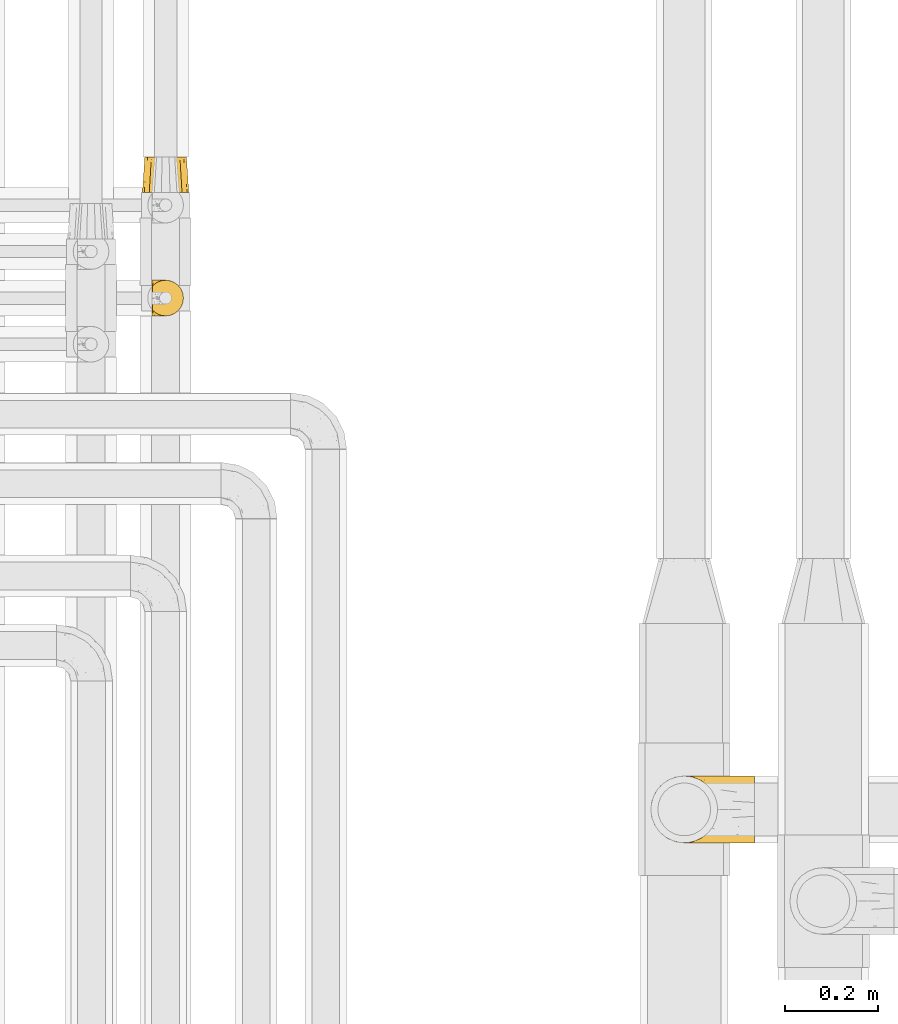
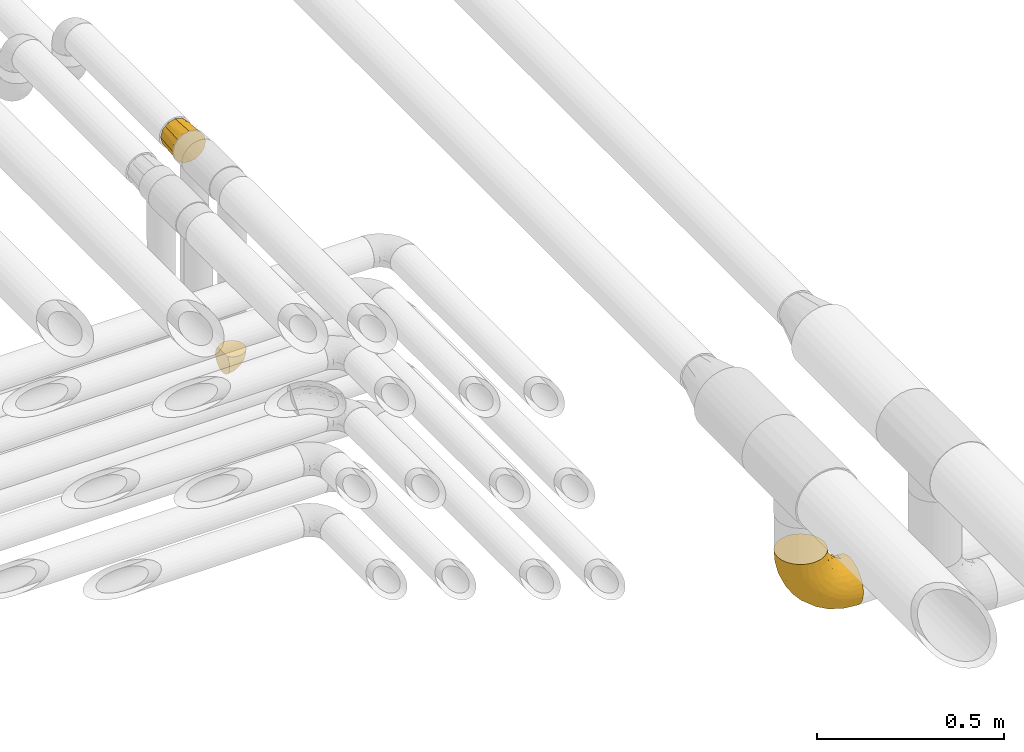
# One storey, part 348 of 827: 3 coverings.
"""IFC2X3 building model written with IfcOpenShell, lengths in millimetres."""

from ifc_helpers import new_model, entity, si_unit, converted_unit, derived_unit, direction, frame, origin, place, context, subcontext, project, spatial, faceted_brep, element, save


model = new_model("IFC2X3")

# Units and contexts
model_context = context("Model", 3, precision=0.01, world=origin(), true_north=direction((6.12303176911189e-17, 1.0)))
body_context = subcontext(model_context, "Body", "Model", "MODEL_VIEW")
ifc_project = project(units=[si_unit("LENGTHUNIT", "METRE", prefix="MILLI"), si_unit("AREAUNIT", "SQUARE_METRE"), si_unit("VOLUMEUNIT", "CUBIC_METRE"), converted_unit("PLANEANGLEUNIT", "DEGREE", entity("IfcRatioMeasure", 0.0174532925199433), si_unit("PLANEANGLEUNIT", "RADIAN"), dimensions=[0, 0, 0, 0, 0, 0, 0]), si_unit("MASSUNIT", "GRAM", prefix="KILO"), derived_unit("MASSDENSITYUNIT", [(si_unit("MASSUNIT", "GRAM", prefix="KILO"), 1), (si_unit("LENGTHUNIT", "METRE"), -3)]), derived_unit("MOMENTOFINERTIAUNIT", [(si_unit("LENGTHUNIT", "METRE"), 4)]), si_unit("TIMEUNIT", "SECOND"), si_unit("FREQUENCYUNIT", "HERTZ"), si_unit("THERMODYNAMICTEMPERATUREUNIT", "DEGREE_CELSIUS"), derived_unit("THERMALTRANSMITTANCEUNIT", [(si_unit("MASSUNIT", "GRAM", prefix="KILO"), 1), (si_unit("THERMODYNAMICTEMPERATUREUNIT", "KELVIN"), -1), (si_unit("TIMEUNIT", "SECOND"), -3)]), derived_unit("VOLUMETRICFLOWRATEUNIT", [(si_unit("LENGTHUNIT", "METRE"), 3), (si_unit("TIMEUNIT", "SECOND"), -1)]), derived_unit("MASSFLOWRATEUNIT", [(si_unit("MASSUNIT", "GRAM", prefix="KILO"), 1), (si_unit("TIMEUNIT", "SECOND"), -1)]), derived_unit("ROTATIONALFREQUENCYUNIT", [(si_unit("TIMEUNIT", "SECOND"), -1)]), si_unit("ELECTRICCURRENTUNIT", "AMPERE"), si_unit("ELECTRICVOLTAGEUNIT", "VOLT"), si_unit("POWERUNIT", "WATT"), si_unit("FORCEUNIT", "NEWTON", prefix="KILO"), si_unit("ILLUMINANCEUNIT", "LUX"), si_unit("LUMINOUSFLUXUNIT", "LUMEN"), si_unit("LUMINOUSINTENSITYUNIT", "CANDELA"), derived_unit("USERDEFINED", [(si_unit("MASSUNIT", "GRAM", prefix="KILO"), -1), (si_unit("LENGTHUNIT", "METRE"), -2), (si_unit("TIMEUNIT", "SECOND"), 3), (si_unit("LUMINOUSFLUXUNIT", "LUMEN"), 1)]), derived_unit("LINEARVELOCITYUNIT", [(si_unit("LENGTHUNIT", "METRE"), 1), (si_unit("TIMEUNIT", "SECOND"), -1)]), si_unit("PRESSUREUNIT", "PASCAL"), derived_unit("USERDEFINED", [(si_unit("LENGTHUNIT", "METRE"), -2), (si_unit("MASSUNIT", "GRAM", prefix="KILO"), 1), (si_unit("TIMEUNIT", "SECOND"), -2)]), derived_unit("LINEARFORCEUNIT", [(si_unit("MASSUNIT", "GRAM", prefix="KILO"), 1), (si_unit("LENGTHUNIT", "METRE"), 1), (si_unit("TIMEUNIT", "SECOND"), -2), (si_unit("LENGTHUNIT", "METRE"), -1)]), derived_unit("PLANARFORCEUNIT", [(si_unit("MASSUNIT", "GRAM", prefix="KILO"), 1), (si_unit("LENGTHUNIT", "METRE"), 1), (si_unit("TIMEUNIT", "SECOND"), -2), (si_unit("LENGTHUNIT", "METRE"), -2)])], contexts=[model_context])

# Site, building, storey
site_placement = place(None, origin())
site = spatial("IfcSite", under=ifc_project, at=site_placement, CompositionType="ELEMENT")
building_placement = place(site_placement, origin())
building = spatial("IfcBuilding", under=site, at=building_placement, CompositionType="ELEMENT")
storey_placement = place(building_placement, frame((0.0, 0.0, 28200.0)))
storey = spatial("IfcBuildingStorey", under=building, at=storey_placement, Name="08", CompositionType="ELEMENT", Elevation=28200.0)

# Coverings
covering_1_placement = place(storey_placement, frame((37674.55, 14212.87, 2426.25)))
element("IfcCovering", 1, at=covering_1_placement, inside=storey, Name=":ADSK_", ObjectType=":ADSK_", PredefinedType="INSULATION", context=body_context, shape_type="Brep", body=[
    faceted_brep([(225.75, 7.09, 46.13), (225.75, 13.76, 33.65), (225.75, 22.73, 22.72), (225.75, 33.67, 13.75), (225.75, 46.14, 7.08), (225.75, 59.68, 2.98), (225.75, 73.74, 1.6), (225.75, 87.82, 2.98), (225.75, 101.36, 7.09), (225.75, 113.84, 13.76), (225.75, 124.77, 22.73), (225.75, 133.74, 33.67), (225.75, 140.41, 46.14), (225.75, 144.51, 59.68), (225.75, 145.9, 73.74), (225.75, 144.51, 87.82), (225.75, 140.4, 101.36), (225.75, 133.73, 113.84), (225.75, 124.76, 124.77), (225.75, 113.82, 133.74), (225.75, 101.35, 140.41), (225.75, 87.81, 144.51), (225.75, 73.75, 145.9), (225.75, 59.67, 144.51), (225.75, 46.13, 140.4), (225.75, 33.65, 133.73), (225.75, 22.72, 124.76), (225.75, 13.75, 113.82), (225.75, 7.08, 101.35), (225.75, 2.98, 87.81), (225.75, 1.6, 73.75), (225.75, 2.98, 59.67), (143.44, 92.42, 225.75), (136.23, 109.82, 225.74), (124.76, 124.76, 225.74), (109.82, 136.23, 225.74), (92.42, 143.44, 225.74), (84.65, 144.46, 225.74), (79.2, 145.18, 225.74), (73.75, 145.9, 225.74), (55.07, 143.44, 225.74), (37.67, 136.23, 225.74), (22.73, 124.76, 225.74), (11.26, 109.82, 225.74), (4.05, 92.42, 225.75), (1.6, 73.75, 225.75), (4.05, 55.07, 225.75), (11.26, 37.67, 225.75), (22.73, 22.73, 225.75), (37.67, 11.26, 225.75), (55.07, 4.06, 225.75), (73.75, 1.6, 225.75), (84.65, 3.03, 225.75), (92.42, 4.06, 225.75), (109.82, 11.26, 225.75), (124.76, 22.73, 225.75), (136.23, 37.67, 225.75), (143.44, 55.07, 225.75), (145.9, 73.75, 225.75), (16.43, 52.92, 154.6), (9.07, 47.22, 193.25), (5.89, 60.55, 188.84), (7.22, 73.75, 175.87), (108.09, 57.34, 37.18), (85.99, 73.75, 50.5), (128.49, 73.74, 23.79), (23.79, 73.75, 128.49), (37.13, 57.65, 108.03), (39.29, 43.83, 113.46), (167.21, 6.45, 57.62), (172.22, 12.65, 43.05), (46.33, 10.17, 176.25), (34.5, 18.9, 171.18), (55.02, 21.1, 119.04), (32.06, 33.63, 139.62), (59.58, 12.81, 132.31), (92.55, 14.78, 85.27), (82.09, 8.9, 111.37), (19.08, 31.52, 185.7), (127.92, 14.06, 59.91), (157.18, 2.84, 75.27), (192.56, 2.53, 65.58), (186.4, 1.6, 78.93), (93.69, 3.45, 121.5), (118.27, 1.6, 118.27), (106.19, 1.6, 134.01), (94.11, 1.6, 149.75), (117.85, 30.33, 46.02), (86.62, 25.03, 74.88), (80.82, 36.09, 68.91), (58.88, 4.35, 185.16), (152.59, 21.3, 37.95), (65.25, 6.68, 147.37), (75.81, 2.71, 157.72), (86.52, 1.6, 168.08), (78.92, 1.6, 186.41), (139.85, 43.1, 26.12), (141.68, 60.63, 19.25), (50.5, 73.75, 85.99), (67.89, 62.29, 67.89), (56.62, 33.28, 98.35), (191.26, 19.48, 29.2), (181.26, 29.91, 21.22), (176.2, 54.25, 9.89), (175.87, 73.74, 7.22), (176.94, 41.52, 14.77), (207.91, 1.6, 76.09), (112.56, 7.6, 84.73), (123.6, 2.7, 96.67), (168.08, 1.6, 86.52), (149.75, 1.6, 94.11), (134.01, 1.6, 106.19), (105.77, 41.92, 45.23), (70.54, 48.23, 70.54), (77.51, 1.6, 197.16), (76.09, 1.6, 207.91), (126.18, 8.31, 155.95), (130.86, 14.97, 169.79), (117.94, 9.79, 176.28), (96.79, 4.44, 197.89), (195.29, 23.18, 129.94), (183.03, 30.31, 141.57), (165.17, 18.2, 138.81), (172.91, 10.62, 121.28), (202.59, 14.55, 117.45), (115.33, 13.24, 203.18), (131.63, 25.15, 196.12), (108.44, 3.7, 159.56), (104.92, 5.4, 180.91), (184.54, 2.56, 91.68), (169.65, 3.05, 100.1), (152.03, 8.27, 128.93), (126.29, 4.17, 137.62), (144.69, 3.35, 116.33), (195.19, 73.75, 151.97), (179.61, 60.13, 158.99), (201.14, 61.31, 148.64), (146.67, 40.92, 187.72), (148.36, 56.73, 198.98), (141.84, 45.15, 208.01), (210.45, 51.0, 143.63), (204.25, 36.54, 138.16), (159.51, 55.9, 177.25), (192.89, 6.38, 103.95), (151.97, 73.75, 195.19), (152.28, 19.87, 152.12), (142.76, 11.96, 146.5), (204.54, 3.13, 90.21), (164.67, 30.41, 153.88), (172.61, 44.61, 158.13), (192.7, 48.87, 148.22), (156.94, 38.59, 169.3), (143.04, 22.86, 168.03), (182.24, 73.75, 160.63), (169.28, 73.75, 169.28), (124.82, 16.55, 187.23), (148.93, 73.75, 210.47), (171.95, 86.62, 165.18), (160.38, 96.04, 173.97), (185.42, 135.25, 118.81), (198.38, 140.55, 104.05), (168.08, 143.18, 106.58), (151.44, 91.77, 190.74), (150.75, 107.85, 178.91), (141.98, 104.39, 203.44), (115.33, 134.26, 203.17), (132.15, 122.78, 193.26), (117.94, 137.7, 176.28), (188.41, 113.29, 142.04), (178.82, 125.45, 135.54), (171.06, 118.55, 147.52), (202.05, 97.47, 145.3), (173.14, 99.09, 159.69), (145.51, 92.04, 207.82), (200.64, 123.47, 129.23), (208.21, 110.35, 137.65), (183.88, 144.57, 93.99), (156.35, 118.88, 159.82), (139.04, 129.18, 165.08), (142.36, 119.52, 177.71), (96.79, 143.05, 197.89), (74.92, 145.9, 216.83), (78.92, 145.9, 186.4), (76.09, 145.9, 207.91), (207.11, 132.29, 117.51), (102.26, 143.87, 171.12), (86.52, 145.9, 168.07), (186.81, 87.88, 154.44), (204.52, 144.35, 90.23), (132.62, 139.69, 145.82), (119.23, 144.58, 137.55), (115.23, 142.43, 157.5), (158.84, 138.81, 125.14), (158.39, 129.98, 142.86), (186.4, 145.9, 78.92), (207.91, 145.9, 76.09), (149.75, 145.9, 94.11), (134.01, 145.9, 106.19), (168.08, 145.9, 86.52), (137.44, 143.94, 123.21), (118.27, 145.9, 118.26), (106.19, 145.9, 134.0), (94.11, 145.9, 149.74), (93.78, 144.09, 121.74), (121.43, 144.02, 93.61), (110.1, 139.99, 87.05), (140.86, 134.0, 53.88), (181.07, 135.63, 42.0), (152.58, 126.21, 37.96), (123.54, 116.2, 41.9), (181.25, 117.6, 21.23), (139.82, 104.4, 26.14), (64.03, 144.75, 193.88), (184.92, 143.07, 58.67), (97.06, 104.84, 50.89), (157.76, 144.75, 75.62), (15.97, 92.54, 154.14), (6.14, 86.98, 187.44), (9.3, 100.21, 191.6), (107.96, 89.43, 37.07), (21.41, 115.43, 173.57), (48.9, 138.71, 177.18), (191.26, 128.02, 29.22), (36.77, 87.36, 107.63), (40.28, 102.93, 111.2), (72.17, 143.75, 154.1), (18.74, 104.64, 159.98), (69.01, 92.54, 69.01), (66.17, 106.16, 79.49), (117.79, 125.91, 55.2), (147.18, 140.71, 65.06), (31.19, 129.44, 189.64), (41.92, 127.39, 146.31), (63.37, 139.28, 143.14), (67.13, 129.7, 108.0), (84.28, 139.61, 112.12), (140.71, 92.17, 20.94), (189.87, 106.21, 12.3), (176.18, 93.26, 9.9), (86.59, 122.47, 74.93), (52.07, 117.97, 109.47), (102.42, 133.82, 78.64), (32.57, 112.81, 136.82)], [[[0, 1, 2, 3, 4, 5, 6, 7, 8, 9, 10, 11, 12, 13, 14, 15, 16, 17, 18, 19, 20, 21, 22, 23, 24, 25, 26, 27, 28, 29, 30, 31]], [[32, 33, 34, 35, 36, 37, 38, 39, 40, 41, 42, 43, 44, 45, 46, 47, 48, 49, 50, 51, 52, 53, 54, 55, 56, 57, 58]], [[59, 60, 61]], [[61, 45, 62]], [[63, 64, 65]], [[66, 67, 59]], [[59, 67, 68]], [[69, 70, 0]], [[71, 49, 72]], [[59, 62, 66]], [[60, 47, 46]], [[73, 72, 74]], [[75, 76, 77]], [[78, 48, 47]], [[79, 70, 69]], [[80, 81, 82]], [[78, 72, 48]], [[83, 84, 85, 86]], [[87, 88, 89]], [[50, 90, 51]], [[91, 70, 79]], [[90, 92, 93]], [[93, 86, 94, 95]], [[96, 63, 97]], [[98, 64, 99]], [[100, 88, 73]], [[70, 91, 101]], [[2, 101, 102]], [[4, 103, 5]], [[104, 103, 97]], [[90, 71, 92]], [[3, 102, 105]], [[103, 105, 96]], [[4, 3, 105]], [[74, 100, 73]], [[104, 6, 5]], [[86, 93, 83]], [[101, 2, 1]], [[88, 100, 89]], [[81, 69, 31]], [[81, 30, 106, 82]], [[48, 72, 49]], [[107, 80, 108]], [[69, 0, 31]], [[74, 78, 59]], [[80, 82, 109, 110]], [[77, 83, 92]], [[83, 108, 84]], [[3, 2, 102]], [[66, 98, 67]], [[87, 102, 91]], [[97, 63, 65]], [[108, 110, 111, 84]], [[104, 5, 103]], [[107, 69, 80]], [[112, 96, 87]], [[99, 63, 113]], [[90, 95, 114, 115, 51]], [[83, 93, 92]], [[99, 67, 98]], [[113, 100, 68]], [[90, 93, 95]], [[71, 50, 49]], [[71, 90, 50]], [[75, 72, 73]], [[1, 0, 70]], [[102, 101, 91]], [[70, 101, 1]], [[79, 69, 107]], [[76, 79, 107]], [[87, 79, 88]], [[76, 88, 79]], [[75, 71, 72]], [[77, 76, 107]], [[73, 88, 76]], [[83, 77, 107]], [[75, 77, 92]], [[71, 75, 92]], [[76, 75, 73]], [[78, 47, 60]], [[72, 78, 74]], [[69, 81, 80]], [[30, 81, 31]], [[68, 100, 74]], [[89, 100, 113]], [[59, 68, 74]], [[113, 68, 67]], [[63, 99, 64]], [[67, 99, 113]], [[112, 113, 63]], [[87, 91, 79]], [[112, 87, 89]], [[102, 87, 96]], [[113, 112, 89]], [[63, 96, 112]], [[107, 108, 83]], [[110, 108, 80]], [[61, 60, 46]], [[78, 60, 59]], [[45, 61, 46]], [[59, 61, 62]], [[4, 105, 103]], [[102, 96, 105]], [[104, 97, 65]], [[96, 97, 103]], [[116, 117, 118]], [[119, 114, 95]], [[119, 53, 114]], [[120, 121, 122]], [[54, 53, 119]], [[123, 124, 120]], [[125, 126, 55]], [[94, 127, 128]], [[109, 129, 130]], [[131, 132, 133]], [[134, 135, 136]], [[55, 54, 125]], [[137, 138, 139]], [[120, 26, 25]], [[140, 141, 24]], [[58, 57, 138]], [[142, 138, 137]], [[143, 123, 130]], [[142, 144, 138]], [[122, 145, 146]], [[120, 25, 141]], [[143, 27, 124]], [[26, 124, 27]], [[127, 85, 132]], [[143, 28, 27]], [[120, 124, 26]], [[57, 56, 139]], [[28, 147, 29]], [[147, 106, 29]], [[148, 121, 149]], [[25, 24, 141]], [[150, 149, 121]], [[136, 22, 134]], [[150, 140, 136]], [[126, 137, 139]], [[56, 55, 126]], [[84, 133, 132]], [[135, 150, 136]], [[23, 140, 24]], [[130, 133, 110]], [[123, 143, 124]], [[121, 120, 141]], [[119, 128, 125]], [[143, 130, 129]], [[28, 143, 147]], [[94, 86, 127]], [[109, 130, 110]], [[147, 129, 82]], [[133, 84, 111, 110]], [[130, 123, 133]], [[133, 123, 131]], [[148, 122, 121]], [[148, 151, 152]], [[146, 116, 132]], [[116, 127, 132]], [[150, 121, 141]], [[145, 148, 152]], [[131, 122, 146]], [[120, 122, 123]], [[23, 22, 136]], [[141, 140, 150]], [[23, 136, 140]], [[135, 134, 153, 154]], [[142, 135, 154]], [[150, 135, 149]], [[144, 142, 154]], [[149, 151, 148]], [[135, 142, 149]], [[151, 142, 137]], [[142, 151, 149]], [[152, 137, 126]], [[137, 152, 151]], [[126, 155, 117]], [[119, 125, 54]], [[155, 118, 117]], [[138, 144, 156, 58]], [[139, 138, 57]], [[106, 147, 82]], [[106, 30, 29]], [[126, 139, 56]], [[82, 129, 109]], [[143, 129, 147]], [[52, 51, 115, 114, 53]], [[119, 95, 94]], [[122, 131, 123]], [[132, 131, 146]], [[117, 146, 152]], [[127, 116, 118]], [[128, 127, 118]], [[148, 145, 122]], [[146, 117, 116]], [[126, 117, 152]], [[126, 125, 155]], [[125, 118, 155]], [[125, 128, 118]], [[94, 128, 119]], [[85, 127, 86]], [[85, 84, 132]], [[152, 146, 145]], [[157, 158, 154]], [[159, 160, 161]], [[162, 163, 164]], [[165, 166, 167]], [[168, 169, 170]], [[164, 166, 33]], [[171, 168, 172]], [[173, 162, 164]], [[134, 21, 171]], [[174, 168, 175]], [[161, 160, 176]], [[177, 178, 179]], [[35, 180, 36]], [[181, 39, 38, 37, 36, 182, 183]], [[184, 174, 18]], [[35, 34, 165]], [[158, 162, 154]], [[180, 185, 186]], [[34, 33, 166]], [[134, 171, 187]], [[171, 175, 168]], [[134, 22, 21]], [[15, 188, 16]], [[189, 190, 191]], [[175, 171, 20]], [[33, 32, 164]], [[20, 171, 21]], [[17, 184, 18]], [[18, 174, 19]], [[160, 17, 16]], [[192, 159, 161]], [[188, 176, 160]], [[174, 169, 168]], [[160, 159, 184]], [[189, 178, 193]], [[193, 192, 189]], [[159, 192, 169]], [[194, 188, 195]], [[188, 15, 195]], [[153, 187, 157]], [[178, 177, 193]], [[192, 193, 169]], [[20, 19, 175]], [[174, 175, 19]], [[161, 196, 197]], [[173, 58, 156, 144]], [[164, 163, 179]], [[165, 180, 35]], [[180, 165, 185]], [[164, 32, 173]], [[154, 162, 144]], [[198, 176, 194]], [[160, 16, 188]], [[161, 198, 196]], [[160, 184, 17]], [[174, 184, 159]], [[161, 197, 199]], [[167, 166, 178]], [[192, 161, 199]], [[189, 199, 190]], [[197, 200, 199]], [[190, 199, 200]], [[189, 192, 199]], [[190, 200, 201]], [[202, 185, 191]], [[166, 165, 34]], [[165, 167, 185]], [[167, 178, 189]], [[179, 178, 166]], [[163, 172, 177]], [[170, 172, 168]], [[15, 14, 195]], [[159, 169, 174]], [[191, 201, 202]], [[170, 193, 177]], [[193, 170, 169]], [[172, 170, 177]], [[194, 176, 188]], [[161, 176, 198]], [[173, 144, 162]], [[182, 36, 180]], [[187, 172, 157]], [[153, 134, 187]], [[171, 172, 187]], [[157, 172, 158]], [[153, 157, 154]], [[172, 163, 158]], [[163, 162, 158]], [[191, 185, 167]], [[186, 182, 180]], [[189, 191, 167]], [[191, 190, 201]], [[185, 202, 186]], [[164, 179, 166]], [[177, 179, 163]], [[58, 173, 32]], [[203, 204, 205]], [[206, 207, 208]], [[209, 210, 211]], [[212, 39, 181, 183, 182]], [[207, 213, 12]], [[214, 209, 211]], [[215, 196, 198, 194]], [[200, 204, 203]], [[66, 62, 216]], [[10, 9, 210]], [[45, 44, 217]], [[218, 216, 217]], [[64, 219, 65]], [[220, 43, 42]], [[214, 211, 219]], [[212, 221, 40]], [[222, 207, 11]], [[223, 216, 224]], [[225, 182, 186, 202]], [[216, 218, 226]], [[227, 228, 214]], [[209, 229, 208]], [[204, 215, 230]], [[207, 230, 213]], [[219, 64, 227]], [[231, 42, 41]], [[14, 13, 213]], [[230, 215, 213]], [[207, 12, 11]], [[230, 206, 205]], [[98, 223, 227]], [[232, 233, 234]], [[212, 182, 225]], [[204, 200, 197, 196]], [[203, 235, 225]], [[222, 210, 208]], [[66, 223, 98]], [[64, 98, 227]], [[65, 219, 236]], [[222, 11, 10]], [[211, 210, 237]], [[7, 104, 238]], [[6, 104, 7]], [[239, 240, 234]], [[240, 228, 224]], [[7, 238, 8]], [[237, 8, 238]], [[40, 221, 41]], [[236, 104, 65]], [[234, 241, 239]], [[9, 8, 237]], [[42, 231, 220]], [[43, 218, 44]], [[232, 240, 242]], [[220, 226, 218]], [[214, 219, 227]], [[238, 236, 211]], [[235, 233, 225]], [[231, 221, 232]], [[210, 222, 10]], [[207, 222, 208]], [[228, 227, 224]], [[239, 229, 209]], [[216, 223, 66]], [[227, 223, 224]], [[239, 209, 214]], [[210, 209, 208]], [[242, 224, 226]], [[239, 214, 228]], [[234, 240, 232]], [[239, 228, 240]], [[233, 232, 221]], [[241, 234, 235]], [[205, 241, 235]], [[229, 206, 208]], [[239, 241, 229]], [[241, 205, 206]], [[241, 206, 229]], [[207, 206, 230]], [[221, 231, 41]], [[220, 231, 232]], [[196, 215, 204]], [[213, 194, 195, 14]], [[194, 213, 215]], [[213, 13, 12]], [[220, 218, 43]], [[217, 216, 62]], [[45, 217, 62]], [[44, 218, 217]], [[242, 226, 220]], [[224, 216, 226]], [[232, 242, 220]], [[224, 242, 240]], [[221, 212, 225]], [[39, 212, 40]], [[225, 202, 203]], [[203, 202, 201, 200]], [[211, 237, 238]], [[9, 237, 210]], [[236, 238, 104]], [[219, 211, 236]], [[234, 233, 235]], [[221, 225, 233]], [[203, 205, 235]], [[230, 205, 204]]]),
])
covering_2_placement = place(storey_placement, frame((36598.95, 15349.55, 2959.95)))
element("IfcCovering", 2, at=covering_2_placement, inside=storey, Name=":ADSK_", ObjectType=":ADSK_", PredefinedType="INSULATION", context=body_context, shape_type="Brep", body=[
    faceted_brep([(1.6, 74.68, 23.36), (1.6, 70.1, 16.07), (1.6, 64.01, 9.98), (1.6, 56.72, 5.4), (1.6, 48.6, 2.56), (1.6, 40.05, 1.6), (1.6, 31.49, 2.56), (1.6, 23.36, 5.41), (1.6, 16.07, 9.99), (1.6, 9.98, 16.08), (1.6, 5.4, 23.37), (1.6, 2.56, 31.49), (1.6, 1.6, 40.05), (1.6, 2.46, 48.15), (1.6, 5.01, 55.88), (1.6, 9.13, 62.9), (1.6, 14.62, 68.89), (1.6, 16.82, 68.89), (1.6, 18.56, 68.89), (1.6, 20.52, 68.89), (1.6, 22.49, 68.89), (1.6, 24.46, 68.89), (1.6, 26.42, 68.89), (1.6, 28.39, 68.89), (1.6, 30.36, 68.89), (1.6, 32.55, 68.89), (1.6, 34.75, 68.89), (1.6, 36.94, 68.89), (1.6, 39.13, 68.89), (1.6, 41.33, 68.89), (1.6, 43.52, 68.89), (1.6, 45.72, 68.89), (1.6, 47.91, 68.89), (1.6, 50.11, 68.89), (1.6, 52.3, 68.89), (1.6, 54.49, 68.89), (1.6, 56.69, 68.89), (1.6, 58.88, 68.89), (1.6, 61.08, 68.89), (1.6, 63.27, 68.89), (1.6, 65.47, 68.89), (1.6, 70.97, 62.89), (1.6, 75.09, 55.86), (1.6, 77.64, 48.13), (1.6, 78.5, 40.05), (1.6, 77.53, 31.49), (1.85, 14.62, 69.15), (7.85, 9.12, 69.15), (14.87, 5.0, 69.15), (22.6, 2.46, 69.15), (30.7, 1.6, 69.15), (40.65, 2.91, 69.15), (49.92, 6.75, 69.15), (57.88, 12.86, 69.15), (63.99, 20.82, 69.15), (67.84, 30.09, 69.15), (69.15, 40.05, 69.15), (67.84, 50.0, 69.15), (63.99, 59.27, 69.15), (57.88, 67.23, 69.15), (49.92, 73.34, 69.15), (40.65, 77.19, 69.15), (30.7, 78.5, 69.15), (22.6, 77.63, 69.15), (14.87, 75.09, 69.15), (7.85, 70.97, 69.15), (1.85, 65.47, 69.15), (1.85, 63.27, 69.15), (1.85, 62.29, 69.15), (1.85, 60.7, 69.15), (1.85, 59.11, 69.15), (1.85, 57.52, 69.15), (1.85, 55.93, 69.15), (1.85, 54.34, 69.15), (1.85, 52.76, 69.15), (1.85, 51.17, 69.15), (1.85, 49.58, 69.15), (1.85, 47.99, 69.15), (1.85, 46.4, 69.15), (1.85, 44.81, 69.15), (1.85, 43.22, 69.15), (1.85, 41.63, 69.15), (1.85, 40.05, 69.15), (1.85, 38.46, 69.15), (1.85, 36.87, 69.15), (1.85, 35.28, 69.15), (1.85, 33.69, 69.15), (1.85, 32.1, 69.15), (1.85, 30.51, 69.15), (1.85, 28.92, 69.15), (1.85, 27.33, 69.15), (1.85, 25.37, 69.15), (1.85, 23.4, 69.15), (1.85, 21.21, 69.15), (1.85, 19.01, 69.15), (1.85, 16.82, 69.15), (1.77, 42.32, 68.96), (1.78, 44.02, 68.97), (1.77, 47.13, 68.97), (1.77, 48.74, 68.97), (1.76, 23.57, 68.95), (1.77, 25.13, 68.96), (1.79, 61.34, 68.98), (1.78, 22.02, 68.97), (1.78, 29.72, 68.97), (1.78, 56.73, 68.98), (1.78, 55.14, 68.97), (1.78, 37.66, 68.97), (1.74, 64.12, 68.94), (1.78, 28.13, 68.98), (1.78, 26.62, 68.98), (1.77, 31.46, 68.96), (1.78, 16.16, 68.97), (1.78, 39.16, 68.98), (1.78, 50.37, 68.98), (1.77, 17.69, 68.97), (1.77, 19.17, 68.96), (1.77, 62.78, 68.97), (1.78, 58.35, 68.97), (1.78, 45.53, 68.98), (1.77, 59.91, 68.96), (1.77, 65.47, 68.97), (1.72, 65.47, 68.94), (1.66, 65.47, 68.92), (1.77, 14.62, 68.97), (1.8, 14.62, 69.02), (1.82, 14.62, 69.08), (1.79, 20.59, 68.98), (1.78, 32.99, 68.97), (1.79, 34.48, 68.98), (1.78, 51.91, 68.97), (1.82, 65.47, 69.08), (1.8, 65.47, 69.02), (1.76, 53.48, 68.96), (1.66, 14.62, 68.92), (1.72, 14.62, 68.94), (1.78, 40.77, 68.97), (1.77, 35.97, 68.96), (9.41, 7.84, 67.02), (17.65, 3.53, 63.33), (7.41, 8.32, 64.61), (15.21, 2.19, 51.4), (7.41, 3.53, 53.1), (16.15, 1.6, 43.94), (28.75, 1.6, 61.87), (13.67, 4.57, 61.54), (12.79, 3.96, 57.95), (19.18, 2.28, 56.12), (29.16, 1.6, 63.4), (9.04, 7.69, 65.41), (5.74, 8.32, 63.04), (3.72, 7.84, 61.33), (8.87, 1.6, 41.99), (21.47, 1.6, 49.27), (26.8, 1.6, 54.6), (9.53, 4.34, 56.6), (7.34, 1.6, 41.58), (37.63, 29.63, 13.72), (17.92, 27.34, 5.82), (27.45, 40.05, 6.74), (37.01, 2.39, 58.82), (34.22, 2.43, 51.58), (45.87, 9.07, 42.09), (56.57, 16.64, 46.12), (52.31, 9.54, 55.56), (42.07, 4.52, 52.38), (44.74, 4.52, 61.54), (21.49, 7.49, 23.76), (11.02, 7.49, 20.5), (15.64, 12.85, 14.64), (26.02, 2.35, 41.77), (36.59, 22.66, 16.28), (65.49, 32.9, 49.4), (63.99, 25.33, 52.34), (15.2, 40.05, 4.3), (60.27, 16.64, 58.67), (45.25, 19.99, 25.26), (35.21, 16.37, 20.17), (22.52, 3.26, 34.7), (12.03, 3.75, 28.67), (13.32, 19.58, 8.62), (35.9, 7.5, 33.37), (33.87, 4.04, 41.35), (25.73, 13.94, 17.15), (26.34, 19.58, 12.68), (46.78, 28.21, 21.47), (59.54, 24.75, 41.11), (60.18, 31.42, 37.53), (53.93, 26.2, 30.64), (53.36, 33.36, 26.66), (49.36, 40.05, 21.38), (38.4, 40.05, 14.06), (66.44, 40.05, 55.54), (50.09, 16.14, 35.17), (41.08, 12.85, 29.04), (31.14, 10.47, 24.34), (28.19, 6.49, 29.33), (64.0, 40.05, 43.3), (56.68, 40.05, 32.34), (43.9, 75.57, 57.75), (65.46, 47.37, 49.41), (52.22, 52.91, 27.85), (37.61, 50.46, 13.7), (15.64, 67.23, 14.63), (13.31, 60.5, 8.61), (50.02, 70.55, 48.85), (59.28, 63.45, 54.13), (53.05, 62.61, 37.84), (21.48, 72.6, 23.75), (11.01, 72.6, 20.49), (12.03, 76.34, 28.66), (41.02, 59.34, 20.83), (35.39, 77.76, 55.15), (26.8, 78.5, 54.6), (28.75, 78.5, 61.87), (7.34, 78.5, 41.58), (65.81, 53.16, 57.58), (53.28, 70.55, 59.91), (59.8, 48.88, 36.94), (61.82, 54.76, 45.72), (17.91, 52.74, 5.82), (41.4, 71.93, 37.91), (40.48, 75.79, 50.18), (26.34, 60.5, 12.67), (31.68, 77.86, 49.29), (27.68, 77.64, 42.64), (16.15, 78.5, 43.94), (21.47, 78.5, 49.27), (28.05, 67.23, 19.45), (22.54, 76.82, 34.7), (8.87, 78.5, 41.99), (37.3, 77.8, 62.29), (41.07, 67.23, 29.01), (32.24, 73.2, 31.47), (47.4, 67.66, 37.18), (35.77, 75.99, 43.45), (17.65, 76.57, 63.33), (11.06, 73.21, 67.23), (8.55, 71.93, 66.07), (6.63, 71.07, 65.22), (12.77, 75.09, 61.99), (12.79, 76.13, 57.95), (7.41, 76.57, 53.09), (18.97, 77.69, 56.84), (3.72, 72.26, 61.33), (5.76, 71.77, 63.06), (15.21, 77.9, 51.41), (9.52, 75.75, 56.61)], [[[0, 1, 2, 3, 4, 5, 6, 7, 8, 9, 10, 11, 12, 13, 14, 15, 16, 17, 18, 19, 20, 21, 22, 23, 24, 25, 26, 27, 28, 29, 30, 31, 32, 33, 34, 35, 36, 37, 38, 39, 40, 41, 42, 43, 44, 45]], [[46, 47, 48, 49, 50, 51, 52, 53, 54, 55, 56, 57, 58, 59, 60, 61, 62, 63, 64, 65, 66, 67, 68, 69, 70, 71, 72, 73, 74, 75, 76, 77, 78, 79, 80, 81, 82, 83, 84, 85, 86, 87, 88, 89, 90, 91, 92, 93, 94, 95]], [[96, 97, 30]], [[98, 77, 99]], [[100, 101, 21]], [[69, 68, 102]], [[20, 19, 103]], [[24, 23, 104]], [[20, 103, 100]], [[72, 105, 106]], [[84, 83, 107]], [[89, 88, 104]], [[108, 67, 66]], [[109, 110, 90]], [[111, 25, 24]], [[112, 17, 16]], [[82, 113, 83]], [[109, 23, 22]], [[114, 76, 75]], [[105, 36, 106]], [[104, 111, 24]], [[18, 115, 116]], [[97, 96, 80]], [[67, 108, 117]], [[105, 71, 118]], [[31, 97, 119]], [[102, 120, 69]], [[108, 121, 122, 123, 40]], [[112, 95, 115]], [[17, 115, 18]], [[94, 116, 115]], [[117, 68, 67]], [[38, 117, 39]], [[112, 124, 125, 126, 46]], [[17, 112, 115]], [[70, 120, 118]], [[39, 117, 108]], [[120, 38, 37]], [[120, 37, 118]], [[120, 70, 69]], [[116, 94, 127]], [[128, 86, 129]], [[117, 38, 102]], [[74, 130, 75]], [[99, 33, 32]], [[115, 95, 94]], [[39, 108, 40]], [[108, 66, 131, 132, 121]], [[105, 72, 71]], [[118, 37, 36]], [[71, 70, 118]], [[35, 106, 36]], [[36, 105, 118]], [[35, 133, 106]], [[74, 73, 133]], [[106, 133, 73]], [[99, 114, 33]], [[133, 35, 34]], [[73, 72, 106]], [[95, 112, 46]], [[112, 16, 134, 135, 124]], [[130, 114, 75]], [[99, 76, 114]], [[114, 130, 33]], [[34, 33, 130]], [[78, 77, 98]], [[98, 119, 78]], [[130, 133, 34]], [[133, 130, 74]], [[79, 97, 80]], [[98, 99, 32]], [[98, 32, 31]], [[77, 76, 99]], [[97, 79, 119]], [[136, 96, 29]], [[30, 97, 31]], [[136, 29, 28]], [[81, 80, 96]], [[29, 96, 30]], [[31, 119, 98]], [[119, 79, 78]], [[96, 136, 81]], [[82, 81, 136]], [[113, 107, 83]], [[84, 107, 137]], [[107, 27, 137]], [[113, 28, 107]], [[27, 107, 28]], [[85, 84, 137]], [[137, 27, 26]], [[113, 136, 28]], [[136, 113, 82]], [[109, 89, 104]], [[86, 85, 129]], [[89, 109, 90]], [[111, 87, 128]], [[26, 129, 137]], [[88, 111, 104]], [[25, 111, 128]], [[22, 110, 109]], [[23, 109, 104]], [[110, 91, 90]], [[100, 92, 101]], [[110, 22, 101]], [[91, 110, 101]], [[116, 19, 18]], [[111, 88, 87]], [[127, 103, 19]], [[25, 128, 26]], [[86, 128, 87]], [[128, 129, 26]], [[137, 129, 85]], [[120, 102, 38]], [[117, 102, 68]], [[91, 101, 92]], [[21, 101, 22]], [[93, 92, 103]], [[100, 21, 20]], [[100, 103, 92]], [[127, 93, 103]], [[93, 127, 94]], [[116, 127, 19]], [[126, 138, 47]], [[48, 138, 139]], [[140, 125, 124]], [[141, 142, 143]], [[144, 49, 139]], [[145, 140, 146]], [[48, 139, 49]], [[139, 145, 147]], [[49, 144, 148, 50]], [[126, 125, 149]], [[14, 13, 142]], [[150, 146, 140]], [[149, 140, 145]], [[151, 150, 135]], [[151, 14, 142]], [[16, 15, 134]], [[13, 152, 142]], [[124, 150, 140]], [[141, 143, 153]], [[14, 151, 15]], [[15, 151, 134]], [[47, 46, 126]], [[139, 154, 144]], [[138, 48, 47]], [[125, 140, 149]], [[135, 134, 151]], [[146, 155, 141]], [[145, 146, 147]], [[149, 139, 138]], [[147, 153, 154]], [[147, 146, 141]], [[139, 147, 154]], [[139, 149, 145]], [[149, 138, 126]], [[147, 141, 153]], [[146, 150, 155]], [[151, 155, 150]], [[142, 141, 155]], [[13, 12, 156, 152]], [[152, 143, 142]], [[151, 142, 155]], [[150, 124, 135]], [[157, 158, 159]], [[160, 154, 161]], [[162, 163, 164]], [[165, 166, 160]], [[167, 168, 169]], [[153, 170, 161]], [[156, 12, 11]], [[158, 157, 171]], [[172, 55, 173]], [[158, 6, 174]], [[175, 54, 53]], [[52, 166, 164]], [[52, 164, 53]], [[54, 175, 173]], [[166, 52, 51]], [[176, 177, 171]], [[178, 143, 179]], [[156, 11, 179]], [[8, 7, 180]], [[169, 9, 8]], [[179, 143, 152, 156]], [[179, 11, 10]], [[168, 179, 10]], [[181, 162, 182]], [[179, 167, 178]], [[183, 184, 177]], [[183, 169, 184]], [[176, 171, 185]], [[172, 186, 187]], [[158, 7, 6]], [[159, 158, 174]], [[184, 180, 158]], [[54, 173, 55]], [[180, 169, 8]], [[188, 189, 187]], [[9, 168, 10]], [[186, 188, 187]], [[190, 157, 159, 191]], [[55, 172, 192]], [[176, 193, 194]], [[161, 170, 182]], [[162, 164, 165]], [[175, 164, 163]], [[51, 50, 148]], [[167, 195, 196]], [[178, 182, 170]], [[6, 5, 174]], [[158, 180, 7]], [[169, 180, 184]], [[169, 168, 9]], [[179, 168, 167]], [[182, 162, 165]], [[162, 194, 193]], [[161, 165, 160]], [[195, 181, 196]], [[192, 172, 197]], [[192, 56, 55]], [[189, 190, 198]], [[198, 197, 187]], [[172, 187, 197]], [[185, 189, 188]], [[198, 187, 189]], [[186, 172, 173]], [[173, 163, 186]], [[193, 186, 163]], [[176, 185, 188]], [[185, 157, 190]], [[188, 186, 193]], [[177, 176, 194]], [[188, 193, 176]], [[162, 193, 163]], [[195, 177, 194]], [[171, 177, 184]], [[181, 195, 194]], [[183, 167, 169]], [[162, 181, 194]], [[196, 182, 178]], [[158, 171, 184]], [[171, 157, 185]], [[177, 195, 183]], [[167, 183, 195]], [[182, 196, 181]], [[178, 170, 143]], [[178, 167, 196]], [[164, 175, 53]], [[173, 175, 163]], [[160, 51, 148]], [[164, 166, 165]], [[51, 160, 166]], [[160, 148, 144, 154]], [[153, 161, 154]], [[182, 165, 161]], [[190, 189, 185]], [[143, 170, 153]], [[60, 199, 61]], [[197, 200, 192]], [[201, 190, 202]], [[200, 57, 192]], [[203, 204, 2]], [[205, 206, 207]], [[208, 209, 210]], [[211, 207, 201]], [[212, 213, 214]], [[45, 215, 210]], [[216, 206, 58]], [[45, 44, 215]], [[59, 217, 60]], [[60, 217, 199]], [[0, 45, 210]], [[218, 201, 219]], [[202, 159, 220]], [[205, 221, 222]], [[223, 204, 203]], [[1, 203, 2]], [[57, 200, 216]], [[220, 3, 204]], [[220, 174, 4]], [[1, 0, 209]], [[212, 224, 213]], [[225, 226, 227]], [[228, 223, 203]], [[208, 210, 229]], [[210, 226, 229]], [[3, 220, 4]], [[58, 206, 59]], [[209, 203, 1]], [[202, 220, 223]], [[228, 203, 208]], [[202, 211, 201]], [[3, 2, 204]], [[202, 190, 191, 159]], [[210, 215, 230, 226]], [[199, 212, 231]], [[232, 233, 221]], [[233, 208, 229]], [[207, 206, 219]], [[217, 206, 205]], [[227, 224, 225]], [[233, 232, 228]], [[201, 207, 219]], [[234, 232, 221]], [[218, 219, 200]], [[202, 223, 211]], [[174, 220, 159]], [[174, 5, 4]], [[61, 231, 62]], [[220, 204, 223]], [[210, 209, 0]], [[203, 209, 208]], [[225, 233, 229]], [[224, 227, 213]], [[221, 233, 235]], [[57, 56, 192]], [[198, 218, 197]], [[200, 219, 216]], [[201, 198, 190]], [[197, 218, 200]], [[198, 201, 218]], [[206, 216, 219]], [[58, 57, 216]], [[231, 212, 214]], [[222, 212, 199]], [[228, 211, 223]], [[207, 211, 232]], [[62, 231, 214]], [[199, 231, 61]], [[233, 228, 208]], [[211, 228, 232]], [[222, 221, 235]], [[234, 205, 207]], [[206, 217, 59]], [[199, 217, 205]], [[205, 222, 199]], [[224, 222, 235]], [[222, 224, 212]], [[224, 235, 225]], [[233, 225, 235]], [[226, 225, 229]], [[205, 234, 221]], [[207, 232, 234]], [[63, 214, 236]], [[214, 213, 236]], [[214, 63, 62]], [[237, 236, 238]], [[238, 132, 131]], [[236, 237, 64]], [[239, 240, 241]], [[63, 236, 64]], [[131, 66, 65]], [[237, 131, 65]], [[242, 230, 43]], [[237, 65, 64]], [[239, 121, 132]], [[42, 242, 43]], [[241, 240, 243]], [[41, 123, 244]], [[43, 230, 215, 44]], [[244, 122, 245]], [[227, 246, 243]], [[241, 247, 245]], [[121, 239, 245]], [[41, 40, 123]], [[132, 238, 239]], [[244, 42, 41]], [[131, 237, 238]], [[240, 239, 238]], [[245, 239, 241]], [[247, 241, 246]], [[247, 244, 245]], [[238, 236, 240]], [[243, 236, 213]], [[236, 243, 240]], [[227, 226, 246]], [[243, 213, 227]], [[242, 246, 226]], [[243, 246, 241]], [[246, 242, 247]], [[244, 247, 242]], [[242, 226, 230]], [[42, 244, 242]], [[122, 244, 123]], [[122, 121, 245]]]),
])
covering_3_placement = place(storey_placement, frame((36578.05, 15617.54, 3498.4)))
element("IfcCovering", 3, at=covering_3_placement, inside=storey, Name=":ADSK_", ObjectType=":ADSK_", PredefinedType="INSULATION", context=body_context, shape_type="Brep", body=[
    faceted_brep([(74.1, 76.0, 90.57), (82.33, 76.0, 82.33), (90.57, 76.0, 74.1), (93.58, 76.0, 62.85), (96.6, 76.0, 51.6), (93.58, 76.0, 40.35), (90.57, 76.0, 29.1), (82.33, 76.0, 20.86), (74.1, 76.0, 12.62), (62.85, 76.0, 9.61), (51.6, 76.0, 6.6), (40.35, 76.0, 9.61), (29.1, 76.0, 12.62), (20.86, 76.0, 20.86), (12.62, 76.0, 29.1), (9.61, 76.0, 40.35), (6.6, 76.0, 51.6), (9.61, 76.0, 62.85), (12.62, 76.0, 74.1), (20.86, 76.0, 82.33), (29.1, 76.0, 90.57), (40.35, 76.0, 93.58), (51.6, 76.0, 96.6), (62.85, 76.0, 93.58), (1.6, 0.0, 51.6), (3.5, 0.0, 42.03), (5.4, 0.0, 32.46), (10.82, 0.0, 24.35), (16.24, 0.0, 16.24), (24.35, 0.0, 10.82), (32.46, 0.0, 5.4), (42.03, 0.0, 3.5), (51.6, 0.0, 1.6), (61.16, 0.0, 3.5), (70.73, 0.0, 5.4), (78.84, 0.0, 10.82), (86.95, 0.0, 16.24), (92.37, 0.0, 24.35), (97.79, 0.0, 32.46), (99.69, 0.0, 42.03), (101.6, 0.0, 51.6), (99.69, 0.0, 61.16), (97.79, 0.0, 70.73), (92.37, 0.0, 78.84), (86.95, 0.0, 86.95), (78.84, 0.0, 92.37), (70.73, 0.0, 97.79), (61.16, 0.0, 99.69), (51.6, 0.0, 101.6), (42.03, 0.0, 99.69), (32.46, 0.0, 97.79), (24.35, 0.0, 92.37), (16.24, 0.0, 86.95), (10.82, 0.0, 78.84), (5.4, 0.0, 70.73), (3.5, 0.0, 61.16)], [[[0, 1, 2, 3, 4, 5, 6, 7, 8, 9, 10, 11, 12, 13, 14, 15, 16, 17, 18, 19, 20, 21, 22, 23]], [[24, 25, 26, 27, 28, 29, 30, 31, 32, 33, 34, 35, 36, 37, 38, 39, 40, 41, 42, 43, 44, 45, 46, 47, 48, 49, 50, 51, 52, 53, 54, 55]], [[49, 48, 22]], [[51, 50, 20]], [[51, 20, 19]], [[18, 53, 19]], [[51, 19, 52]], [[55, 16, 24]], [[22, 21, 49]], [[53, 52, 19]], [[16, 55, 17]], [[21, 20, 50]], [[21, 50, 49]], [[54, 18, 17]], [[55, 54, 17]], [[18, 54, 53]], [[41, 40, 4]], [[43, 42, 2]], [[43, 2, 1]], [[0, 45, 1]], [[43, 1, 44]], [[47, 22, 48]], [[4, 3, 41]], [[45, 44, 1]], [[22, 47, 23]], [[3, 2, 42]], [[3, 42, 41]], [[46, 0, 23]], [[47, 46, 23]], [[0, 46, 45]], [[33, 32, 10]], [[35, 34, 8]], [[35, 8, 7]], [[6, 37, 7]], [[35, 7, 36]], [[39, 4, 40]], [[10, 9, 33]], [[37, 36, 7]], [[4, 39, 5]], [[9, 8, 34]], [[9, 34, 33]], [[38, 6, 5]], [[39, 38, 5]], [[6, 38, 37]], [[25, 24, 16]], [[27, 26, 14]], [[27, 14, 13]], [[12, 29, 13]], [[27, 13, 28]], [[31, 10, 32]], [[16, 15, 25]], [[29, 28, 13]], [[10, 31, 11]], [[15, 14, 26]], [[15, 26, 25]], [[30, 12, 11]], [[31, 30, 11]], [[12, 30, 29]]]),
])

save(model, "model.ifc")
